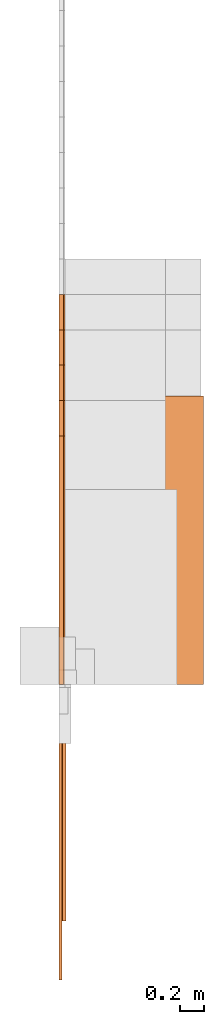
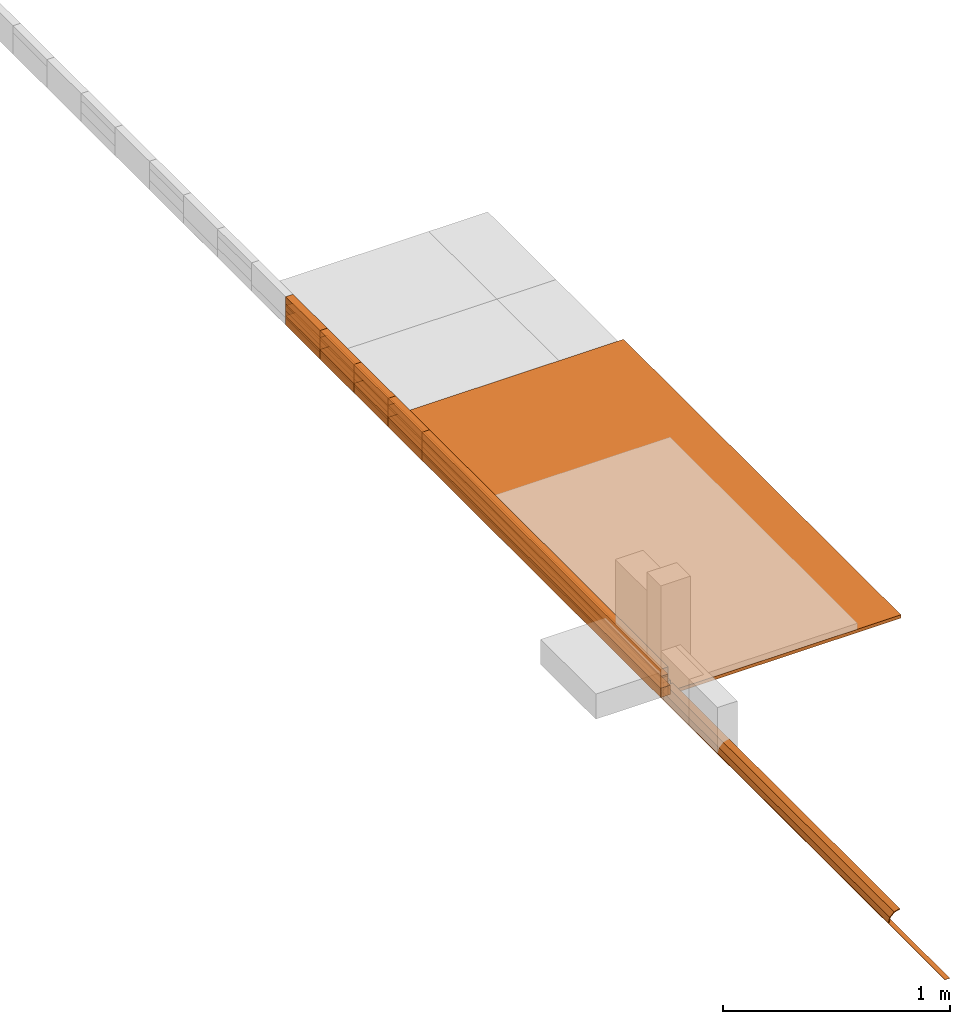
# Not in any storey, part 1 of 5: 39 proxies.
"""IFC4 model written with IfcOpenShell, lengths in metres."""

from ifc_helpers import new_model, entity, si_unit, converted_unit, direction, origin_with_axes, place, context, subcontext, project, faceted_brep, element, save


model = new_model("IFC4")

# Units and contexts
model_context = context("Model", 3, precision=1e-05, world=origin_with_axes(), true_north=direction((0.0, 1.0)))
body_context = subcontext(model_context, "Body", "Model", "MODEL_VIEW")
ifc_project = project(units=[si_unit("LENGTHUNIT", "METRE"), si_unit("AREAUNIT", "SQUARE_METRE"), si_unit("VOLUMEUNIT", "CUBIC_METRE"), converted_unit("PLANEANGLEUNIT", "DEGREE", entity("IfcPlaneAngleMeasure", 0.017453292519943295), si_unit("PLANEANGLEUNIT", "RADIAN"), dimensions=[0, 0, 0, 0, 0, 0, 0])], contexts=[model_context])

# Proxies
proxy_1_placement = place(None, origin_with_axes())
element("IfcBuildingElementProxy", 1, at=proxy_1_placement, Name="1220x2440x18", context=body_context, shape_type="Brep", body=[
    faceted_brep([(1.22, 0.0, 0.0), (1.22, 0.0, 0.018), (0.0, 0.0, 0.018), (0.0, 0.0, 0.0), (1.22, 2.44, 0.0), (1.22, 2.44, 0.018), (1.22, 0.0, 0.018), (1.22, 0.0, 0.0), (0.0, 2.44, 0.0), (0.0, 2.44, 0.018), (1.22, 2.44, 0.018), (1.22, 2.44, 0.0), (0.0, 0.0, 0.0), (0.0, 0.0, 0.018), (0.0, 2.44, 0.018), (0.0, 2.44, 0.0), (0.0, 2.44, 0.0), (1.22, 2.44, 0.0), (1.22, 0.0, 0.0), (0.0, 0.0, 0.0), (0.0, 0.0, 0.018), (1.22, 0.0, 0.018), (1.22, 2.44, 0.018), (0.0, 2.44, 0.018)], [[[0, 1, 2, 3]], [[4, 5, 6, 7]], [[8, 9, 10, 11]], [[12, 13, 14, 15]], [[16, 17, 18, 19]], [[20, 21, 22, 23]]]),
])
proxy_2_placement = place(None, origin_with_axes())
element("IfcBuildingElementProxy", 2, at=proxy_2_placement, Name="Timber 114x38x2100", context=body_context, shape_type="Brep", body=[
    faceted_brep([(0.038, 0.0, 0.0), (0.038, 0.0, 0.114), (0.0, 0.0, 0.114), (0.0, 0.0, 0.0), (0.038, 2.1, 0.0), (0.038, 2.1, 0.114), (0.038, 0.0, 0.114), (0.038, 0.0, 0.0), (0.0, 2.1, 0.0), (0.0, 2.1, 0.114), (0.038, 2.1, 0.114), (0.038, 2.1, 0.0), (0.0, 0.0, 0.0), (0.0, 0.0, 0.114), (0.0, 2.1, 0.114), (0.0, 2.1, 0.0), (0.0, 2.1, 0.0), (0.038, 2.1, 0.0), (0.038, 0.0, 0.0), (0.0, 0.0, 0.0), (0.0, 0.0, 0.114), (0.038, 0.0, 0.114), (0.038, 2.1, 0.114), (0.0, 2.1, 0.114)], [[[0, 1, 2, 3]], [[4, 5, 6, 7]], [[8, 9, 10, 11]], [[12, 13, 14, 15]], [[16, 17, 18, 19]], [[20, 21, 22, 23]]]),
])
proxy_3_placement = place(None, origin_with_axes())
element("IfcBuildingElementProxy", 3, at=proxy_3_placement, Name="Timber 114x38x2400", context=body_context, shape_type="Brep", body=[
    faceted_brep([(0.038, 0.0, 0.0), (0.038, 0.0, 0.114), (0.0, 0.0, 0.114), (0.0, 0.0, 0.0), (0.038, 2.4, 0.0), (0.038, 2.4, 0.114), (0.038, 0.0, 0.114), (0.038, 0.0, 0.0), (0.0, 2.4, 0.0), (0.0, 2.4, 0.114), (0.038, 2.4, 0.114), (0.038, 2.4, 0.0), (0.0, 0.0, 0.0), (0.0, 0.0, 0.114), (0.0, 2.4, 0.114), (0.0, 2.4, 0.0), (0.0, 2.4, 0.0), (0.038, 2.4, 0.0), (0.038, 0.0, 0.0), (0.0, 0.0, 0.0), (0.0, 0.0, 0.114), (0.038, 0.0, 0.114), (0.038, 2.4, 0.114), (0.0, 2.4, 0.114)], [[[0, 1, 2, 3]], [[4, 5, 6, 7]], [[8, 9, 10, 11]], [[12, 13, 14, 15]], [[16, 17, 18, 19]], [[20, 21, 22, 23]]]),
])
proxy_4_placement = place(None, origin_with_axes())
element("IfcBuildingElementProxy", 4, at=proxy_4_placement, Name="Timber 114x38x2700", context=body_context, shape_type="Brep", body=[
    faceted_brep([(0.038, 0.0, 0.0), (0.038, 0.0, 0.114), (0.0, 0.0, 0.114), (0.0, 0.0, 0.0), (0.038, 2.7, 0.0), (0.038, 2.7, 0.114), (0.038, 0.0, 0.114), (0.038, 0.0, 0.0), (0.0, 2.7, 0.0), (0.0, 2.7, 0.114), (0.038, 2.7, 0.114), (0.038, 2.7, 0.0), (0.0, 0.0, 0.0), (0.0, 0.0, 0.114), (0.0, 2.7, 0.114), (0.0, 2.7, 0.0), (0.0, 2.7, 0.0), (0.038, 2.7, 0.0), (0.038, 0.0, 0.0), (0.0, 0.0, 0.0), (0.0, 0.0, 0.114), (0.038, 0.0, 0.114), (0.038, 2.7, 0.114), (0.0, 2.7, 0.114)], [[[0, 1, 2, 3]], [[4, 5, 6, 7]], [[8, 9, 10, 11]], [[12, 13, 14, 15]], [[16, 17, 18, 19]], [[20, 21, 22, 23]]]),
])
proxy_5_placement = place(None, origin_with_axes())
element("IfcBuildingElementProxy", 5, at=proxy_5_placement, Name="Timber 114x38x3000", context=body_context, shape_type="Brep", body=[
    faceted_brep([(0.038, 0.0, 0.0), (0.038, 0.0, 0.114), (0.0, 0.0, 0.114), (0.0, 0.0, 0.0), (0.038, 3.0, 0.0), (0.038, 3.0, 0.114), (0.038, 0.0, 0.114), (0.038, 0.0, 0.0), (0.0, 3.0, 0.0), (0.0, 3.0, 0.114), (0.038, 3.0, 0.114), (0.038, 3.0, 0.0), (0.0, 0.0, 0.0), (0.0, 0.0, 0.114), (0.0, 3.0, 0.114), (0.0, 3.0, 0.0), (0.0, 3.0, 0.0), (0.038, 3.0, 0.0), (0.038, 0.0, 0.0), (0.0, 0.0, 0.0), (0.0, 0.0, 0.114), (0.038, 0.0, 0.114), (0.038, 3.0, 0.114), (0.0, 3.0, 0.114)], [[[0, 1, 2, 3]], [[4, 5, 6, 7]], [[8, 9, 10, 11]], [[12, 13, 14, 15]], [[16, 17, 18, 19]], [[20, 21, 22, 23]]]),
])
proxy_6_placement = place(None, origin_with_axes())
element("IfcBuildingElementProxy", 6, at=proxy_6_placement, Name="Timber 114x38x3300", context=body_context, shape_type="Brep", body=[
    faceted_brep([(0.038, 0.0, 0.0), (0.038, 0.0, 0.114), (0.0, 0.0, 0.114), (0.0, 0.0, 0.0), (0.038, 3.3, 0.0), (0.038, 3.3, 0.114), (0.038, 0.0, 0.114), (0.038, 0.0, 0.0), (0.0, 3.3, 0.0), (0.0, 3.3, 0.114), (0.038, 3.3, 0.114), (0.038, 3.3, 0.0), (0.0, 0.0, 0.0), (0.0, 0.0, 0.114), (0.0, 3.3, 0.114), (0.0, 3.3, 0.0), (0.0, 3.3, 0.0), (0.038, 3.3, 0.0), (0.038, 0.0, 0.0), (0.0, 0.0, 0.0), (0.0, 0.0, 0.114), (0.038, 0.0, 0.114), (0.038, 3.3, 0.114), (0.0, 3.3, 0.114)], [[[0, 1, 2, 3]], [[4, 5, 6, 7]], [[8, 9, 10, 11]], [[12, 13, 14, 15]], [[16, 17, 18, 19]], [[20, 21, 22, 23]]]),
])
proxy_7_placement = place(None, origin_with_axes())
element("IfcBuildingElementProxy", 7, at=proxy_7_placement, Name="Timber 38x105x2100", context=body_context, shape_type="Brep", body=[
    faceted_brep([(0.038, 0.0, 0.0), (0.038, 0.0, 0.105), (0.0, 0.0, 0.105), (0.0, 0.0, 0.0), (0.038, 2.1, 0.0), (0.038, 2.1, 0.105), (0.038, 0.0, 0.105), (0.038, 0.0, 0.0), (0.0, 2.1, 0.0), (0.0, 2.1, 0.105), (0.038, 2.1, 0.105), (0.038, 2.1, 0.0), (0.0, 0.0, 0.0), (0.0, 0.0, 0.105), (0.0, 2.1, 0.105), (0.0, 2.1, 0.0), (0.0, 2.1, 0.0), (0.038, 2.1, 0.0), (0.038, 0.0, 0.0), (0.0, 0.0, 0.0), (0.0, 0.0, 0.105), (0.038, 0.0, 0.105), (0.038, 2.1, 0.105), (0.0, 2.1, 0.105)], [[[0, 1, 2, 3]], [[4, 5, 6, 7]], [[8, 9, 10, 11]], [[12, 13, 14, 15]], [[16, 17, 18, 19]], [[20, 21, 22, 23]]]),
])
proxy_8_placement = place(None, origin_with_axes())
element("IfcBuildingElementProxy", 8, at=proxy_8_placement, Name="Timber 38x105x2400", context=body_context, shape_type="Brep", body=[
    faceted_brep([(0.038, 0.0, 0.0), (0.038, 0.0, 0.105), (0.0, 0.0, 0.105), (0.0, 0.0, 0.0), (0.038, 2.4, 0.0), (0.038, 2.4, 0.105), (0.038, 0.0, 0.105), (0.038, 0.0, 0.0), (0.0, 2.4, 0.0), (0.0, 2.4, 0.105), (0.038, 2.4, 0.105), (0.038, 2.4, 0.0), (0.0, 0.0, 0.0), (0.0, 0.0, 0.105), (0.0, 2.4, 0.105), (0.0, 2.4, 0.0), (0.0, 2.4, 0.0), (0.038, 2.4, 0.0), (0.038, 0.0, 0.0), (0.0, 0.0, 0.0), (0.0, 0.0, 0.105), (0.038, 0.0, 0.105), (0.038, 2.4, 0.105), (0.0, 2.4, 0.105)], [[[0, 1, 2, 3]], [[4, 5, 6, 7]], [[8, 9, 10, 11]], [[12, 13, 14, 15]], [[16, 17, 18, 19]], [[20, 21, 22, 23]]]),
])
proxy_9_placement = place(None, origin_with_axes())
element("IfcBuildingElementProxy", 9, at=proxy_9_placement, Name="Timber 38x105x2700", context=body_context, shape_type="Brep", body=[
    faceted_brep([(0.038, 0.0, 0.0), (0.038, 0.0, 0.105), (0.0, 0.0, 0.105), (0.0, 0.0, 0.0), (0.038, 2.7, 0.0), (0.038, 2.7, 0.105), (0.038, 0.0, 0.105), (0.038, 0.0, 0.0), (0.0, 2.7, 0.0), (0.0, 2.7, 0.105), (0.038, 2.7, 0.105), (0.038, 2.7, 0.0), (0.0, 0.0, 0.0), (0.0, 0.0, 0.105), (0.0, 2.7, 0.105), (0.0, 2.7, 0.0), (0.0, 2.7, 0.0), (0.038, 2.7, 0.0), (0.038, 0.0, 0.0), (0.0, 0.0, 0.0), (0.0, 0.0, 0.105), (0.038, 0.0, 0.105), (0.038, 2.7, 0.105), (0.0, 2.7, 0.105)], [[[0, 1, 2, 3]], [[4, 5, 6, 7]], [[8, 9, 10, 11]], [[12, 13, 14, 15]], [[16, 17, 18, 19]], [[20, 21, 22, 23]]]),
])
proxy_10_placement = place(None, origin_with_axes())
element("IfcBuildingElementProxy", 10, at=proxy_10_placement, Name="Timber 38x105x3000", context=body_context, shape_type="Brep", body=[
    faceted_brep([(0.038, 0.0, 0.0), (0.038, 0.0, 0.105), (0.0, 0.0, 0.105), (0.0, 0.0, 0.0), (0.038, 3.0, 0.0), (0.038, 3.0, 0.105), (0.038, 0.0, 0.105), (0.038, 0.0, 0.0), (0.0, 3.0, 0.0), (0.0, 3.0, 0.105), (0.038, 3.0, 0.105), (0.038, 3.0, 0.0), (0.0, 0.0, 0.0), (0.0, 0.0, 0.105), (0.0, 3.0, 0.105), (0.0, 3.0, 0.0), (0.0, 3.0, 0.0), (0.038, 3.0, 0.0), (0.038, 0.0, 0.0), (0.0, 0.0, 0.0), (0.0, 0.0, 0.105), (0.038, 0.0, 0.105), (0.038, 3.0, 0.105), (0.0, 3.0, 0.105)], [[[0, 1, 2, 3]], [[4, 5, 6, 7]], [[8, 9, 10, 11]], [[12, 13, 14, 15]], [[16, 17, 18, 19]], [[20, 21, 22, 23]]]),
])
proxy_11_placement = place(None, origin_with_axes())
element("IfcBuildingElementProxy", 11, at=proxy_11_placement, Name="Timber 38x105x3300", context=body_context, shape_type="Brep", body=[
    faceted_brep([(0.038, 0.0, 0.0), (0.038, 0.0, 0.105), (0.0, 0.0, 0.105), (0.0, 0.0, 0.0), (0.038, 3.3, 0.0), (0.038, 3.3, 0.105), (0.038, 0.0, 0.105), (0.038, 0.0, 0.0), (0.0, 3.3, 0.0), (0.0, 3.3, 0.105), (0.038, 3.3, 0.105), (0.038, 3.3, 0.0), (0.0, 0.0, 0.0), (0.0, 0.0, 0.105), (0.0, 3.3, 0.105), (0.0, 3.3, 0.0), (0.0, 3.3, 0.0), (0.038, 3.3, 0.0), (0.038, 0.0, 0.0), (0.0, 0.0, 0.0), (0.0, 0.0, 0.105), (0.038, 0.0, 0.105), (0.038, 3.3, 0.105), (0.0, 3.3, 0.105)], [[[0, 1, 2, 3]], [[4, 5, 6, 7]], [[8, 9, 10, 11]], [[12, 13, 14, 15]], [[16, 17, 18, 19]], [[20, 21, 22, 23]]]),
])
proxy_12_placement = place(None, origin_with_axes())
element("IfcBuildingElementProxy", 12, at=proxy_12_placement, Name="Timber 38x38x2100", context=body_context, shape_type="Brep", body=[
    faceted_brep([(0.038, 0.0, 0.0), (0.038, 0.0, 0.038), (0.0, 0.0, 0.038), (0.0, 0.0, 0.0), (0.038, 2.1, 0.0), (0.038, 2.1, 0.038), (0.038, 0.0, 0.038), (0.038, 0.0, 0.0), (0.0, 2.1, 0.0), (0.0, 2.1, 0.038), (0.038, 2.1, 0.038), (0.038, 2.1, 0.0), (0.0, 0.0, 0.0), (0.0, 0.0, 0.038), (0.0, 2.1, 0.038), (0.0, 2.1, 0.0), (0.0, 2.1, 0.0), (0.038, 2.1, 0.0), (0.038, 0.0, 0.0), (0.0, 0.0, 0.0), (0.0, 0.0, 0.038), (0.038, 0.0, 0.038), (0.038, 2.1, 0.038), (0.0, 2.1, 0.038)], [[[0, 1, 2, 3]], [[4, 5, 6, 7]], [[8, 9, 10, 11]], [[12, 13, 14, 15]], [[16, 17, 18, 19]], [[20, 21, 22, 23]]]),
])
proxy_13_placement = place(None, origin_with_axes())
element("IfcBuildingElementProxy", 13, at=proxy_13_placement, Name="Timber 38x38x2400", context=body_context, shape_type="Brep", body=[
    faceted_brep([(0.038, 0.0, 0.0), (0.038, 0.0, 0.038), (0.0, 0.0, 0.038), (0.0, 0.0, 0.0), (0.038, 2.4, 0.0), (0.038, 2.4, 0.038), (0.038, 0.0, 0.038), (0.038, 0.0, 0.0), (0.0, 2.4, 0.0), (0.0, 2.4, 0.038), (0.038, 2.4, 0.038), (0.038, 2.4, 0.0), (0.0, 0.0, 0.0), (0.0, 0.0, 0.038), (0.0, 2.4, 0.038), (0.0, 2.4, 0.0), (0.0, 2.4, 0.0), (0.038, 2.4, 0.0), (0.038, 0.0, 0.0), (0.0, 0.0, 0.0), (0.0, 0.0, 0.038), (0.038, 0.0, 0.038), (0.038, 2.4, 0.038), (0.0, 2.4, 0.038)], [[[0, 1, 2, 3]], [[4, 5, 6, 7]], [[8, 9, 10, 11]], [[12, 13, 14, 15]], [[16, 17, 18, 19]], [[20, 21, 22, 23]]]),
])
proxy_14_placement = place(None, origin_with_axes())
element("IfcBuildingElementProxy", 14, at=proxy_14_placement, Name="Timber 38x38x2700", context=body_context, shape_type="Brep", body=[
    faceted_brep([(0.038, 0.0, 0.0), (0.038, 0.0, 0.038), (0.0, 0.0, 0.038), (0.0, 0.0, 0.0), (0.038, 2.7, 0.0), (0.038, 2.7, 0.038), (0.038, 0.0, 0.038), (0.038, 0.0, 0.0), (0.0, 2.7, 0.0), (0.0, 2.7, 0.038), (0.038, 2.7, 0.038), (0.038, 2.7, 0.0), (0.0, 0.0, 0.0), (0.0, 0.0, 0.038), (0.0, 2.7, 0.038), (0.0, 2.7, 0.0), (0.0, 2.7, 0.0), (0.038, 2.7, 0.0), (0.038, 0.0, 0.0), (0.0, 0.0, 0.0), (0.0, 0.0, 0.038), (0.038, 0.0, 0.038), (0.038, 2.7, 0.038), (0.0, 2.7, 0.038)], [[[0, 1, 2, 3]], [[4, 5, 6, 7]], [[8, 9, 10, 11]], [[12, 13, 14, 15]], [[16, 17, 18, 19]], [[20, 21, 22, 23]]]),
])
proxy_15_placement = place(None, origin_with_axes())
element("IfcBuildingElementProxy", 15, at=proxy_15_placement, Name="Timber 38x38x3000", context=body_context, shape_type="Brep", body=[
    faceted_brep([(0.038, 0.0, 0.0), (0.038, 0.0, 0.038), (0.0, 0.0, 0.038), (0.0, 0.0, 0.0), (0.038, 3.0, 0.0), (0.038, 3.0, 0.038), (0.038, 0.0, 0.038), (0.038, 0.0, 0.0), (0.0, 3.0, 0.0), (0.0, 3.0, 0.038), (0.038, 3.0, 0.038), (0.038, 3.0, 0.0), (0.0, 0.0, 0.0), (0.0, 0.0, 0.038), (0.0, 3.0, 0.038), (0.0, 3.0, 0.0), (0.0, 3.0, 0.0), (0.038, 3.0, 0.0), (0.038, 0.0, 0.0), (0.0, 0.0, 0.0), (0.0, 0.0, 0.038), (0.038, 0.0, 0.038), (0.038, 3.0, 0.038), (0.0, 3.0, 0.038)], [[[0, 1, 2, 3]], [[4, 5, 6, 7]], [[8, 9, 10, 11]], [[12, 13, 14, 15]], [[16, 17, 18, 19]], [[20, 21, 22, 23]]]),
])
proxy_16_placement = place(None, origin_with_axes())
element("IfcBuildingElementProxy", 16, at=proxy_16_placement, Name="Timber 38x38x3300", context=body_context, shape_type="Brep", body=[
    faceted_brep([(0.038, 0.0, 0.0), (0.038, 0.0, 0.038), (0.0, 0.0, 0.038), (0.0, 0.0, 0.0), (0.038, 3.3, 0.0), (0.038, 3.3, 0.038), (0.038, 0.0, 0.038), (0.038, 0.0, 0.0), (0.0, 3.3, 0.0), (0.0, 3.3, 0.038), (0.038, 3.3, 0.038), (0.038, 3.3, 0.0), (0.0, 0.0, 0.0), (0.0, 0.0, 0.038), (0.0, 3.3, 0.038), (0.0, 3.3, 0.0), (0.0, 3.3, 0.0), (0.038, 3.3, 0.0), (0.038, 0.0, 0.0), (0.0, 0.0, 0.0), (0.0, 0.0, 0.038), (0.038, 0.0, 0.038), (0.038, 3.3, 0.038), (0.0, 3.3, 0.038)], [[[0, 1, 2, 3]], [[4, 5, 6, 7]], [[8, 9, 10, 11]], [[12, 13, 14, 15]], [[16, 17, 18, 19]], [[20, 21, 22, 23]]]),
])
proxy_17_placement = place(None, origin_with_axes())
element("IfcBuildingElementProxy", 17, at=proxy_17_placement, Name="Timber 38x50x2100", context=body_context, shape_type="Brep", body=[
    faceted_brep([(0.038, 0.0, 0.0), (0.038, 0.0, 0.05), (0.0, 0.0, 0.05), (0.0, 0.0, 0.0), (0.038, 2.1, 0.0), (0.038, 2.1, 0.05), (0.038, 0.0, 0.05), (0.038, 0.0, 0.0), (0.0, 2.1, 0.0), (0.0, 2.1, 0.05), (0.038, 2.1, 0.05), (0.038, 2.1, 0.0), (0.0, 0.0, 0.0), (0.0, 0.0, 0.05), (0.0, 2.1, 0.05), (0.0, 2.1, 0.0), (0.0, 2.1, 0.0), (0.038, 2.1, 0.0), (0.038, 0.0, 0.0), (0.0, 0.0, 0.0), (0.0, 0.0, 0.05), (0.038, 0.0, 0.05), (0.038, 2.1, 0.05), (0.0, 2.1, 0.05)], [[[0, 1, 2, 3]], [[4, 5, 6, 7]], [[8, 9, 10, 11]], [[12, 13, 14, 15]], [[16, 17, 18, 19]], [[20, 21, 22, 23]]]),
])
proxy_18_placement = place(None, origin_with_axes())
element("IfcBuildingElementProxy", 18, at=proxy_18_placement, Name="Timber 38x50x2300", context=body_context, shape_type="Brep", body=[
    faceted_brep([(0.038, 0.0, 0.0), (0.038, 0.0, 0.05), (0.0, 0.0, 0.05), (0.0, 0.0, 0.0), (0.038, 2.4, 0.0), (0.038, 2.4, 0.05), (0.038, 0.0, 0.05), (0.038, 0.0, 0.0), (0.0, 2.4, 0.0), (0.0, 2.4, 0.05), (0.038, 2.4, 0.05), (0.038, 2.4, 0.0), (0.0, 0.0, 0.0), (0.0, 0.0, 0.05), (0.0, 2.4, 0.05), (0.0, 2.4, 0.0), (0.0, 2.4, 0.0), (0.038, 2.4, 0.0), (0.038, 0.0, 0.0), (0.0, 0.0, 0.0), (0.0, 0.0, 0.05), (0.038, 0.0, 0.05), (0.038, 2.4, 0.05), (0.0, 2.4, 0.05)], [[[0, 1, 2, 3]], [[4, 5, 6, 7]], [[8, 9, 10, 11]], [[12, 13, 14, 15]], [[16, 17, 18, 19]], [[20, 21, 22, 23]]]),
])
proxy_19_placement = place(None, origin_with_axes())
element("IfcBuildingElementProxy", 19, at=proxy_19_placement, Name="Timber 38x50x2700", context=body_context, shape_type="Brep", body=[
    faceted_brep([(0.038, 0.0, 0.0), (0.038, 0.0, 0.05), (0.0, 0.0, 0.05), (0.0, 0.0, 0.0), (0.038, 2.7, 0.0), (0.038, 2.7, 0.05), (0.038, 0.0, 0.05), (0.038, 0.0, 0.0), (0.0, 2.7, 0.0), (0.0, 2.7, 0.05), (0.038, 2.7, 0.05), (0.038, 2.7, 0.0), (0.0, 0.0, 0.0), (0.0, 0.0, 0.05), (0.0, 2.7, 0.05), (0.0, 2.7, 0.0), (0.0, 2.7, 0.0), (0.038, 2.7, 0.0), (0.038, 0.0, 0.0), (0.0, 0.0, 0.0), (0.0, 0.0, 0.05), (0.038, 0.0, 0.05), (0.038, 2.7, 0.05), (0.0, 2.7, 0.05)], [[[0, 1, 2, 3]], [[4, 5, 6, 7]], [[8, 9, 10, 11]], [[12, 13, 14, 15]], [[16, 17, 18, 19]], [[20, 21, 22, 23]]]),
])
proxy_20_placement = place(None, origin_with_axes())
element("IfcBuildingElementProxy", 20, at=proxy_20_placement, Name="Timber 38x50x3000", context=body_context, shape_type="Brep", body=[
    faceted_brep([(0.038, 0.0, 0.0), (0.038, 0.0, 0.05), (0.0, 0.0, 0.05), (0.0, 0.0, 0.0), (0.038, 3.0, 0.0), (0.038, 3.0, 0.05), (0.038, 0.0, 0.05), (0.038, 0.0, 0.0), (0.0, 3.0, 0.0), (0.0, 3.0, 0.05), (0.038, 3.0, 0.05), (0.038, 3.0, 0.0), (0.0, 0.0, 0.0), (0.0, 0.0, 0.05), (0.0, 3.0, 0.05), (0.0, 3.0, 0.0), (0.0, 3.0, 0.0), (0.038, 3.0, 0.0), (0.038, 0.0, 0.0), (0.0, 0.0, 0.0), (0.0, 0.0, 0.05), (0.038, 0.0, 0.05), (0.038, 3.0, 0.05), (0.0, 3.0, 0.05)], [[[0, 1, 2, 3]], [[4, 5, 6, 7]], [[8, 9, 10, 11]], [[12, 13, 14, 15]], [[16, 17, 18, 19]], [[20, 21, 22, 23]]]),
])
proxy_21_placement = place(None, origin_with_axes())
element("IfcBuildingElementProxy", 21, at=proxy_21_placement, Name="Timber 38x50x3300", context=body_context, shape_type="Brep", body=[
    faceted_brep([(0.038, 0.0, 0.0), (0.038, 0.0, 0.05), (0.0, 0.0, 0.05), (0.0, 0.0, 0.0), (0.038, 3.3, 0.0), (0.038, 3.3, 0.05), (0.038, 0.0, 0.05), (0.038, 0.0, 0.0), (0.0, 3.3, 0.0), (0.0, 3.3, 0.05), (0.038, 3.3, 0.05), (0.038, 3.3, 0.0), (0.0, 0.0, 0.0), (0.0, 0.0, 0.05), (0.0, 3.3, 0.05), (0.0, 3.3, 0.0), (0.0, 3.3, 0.0), (0.038, 3.3, 0.0), (0.038, 0.0, 0.0), (0.0, 0.0, 0.0), (0.0, 0.0, 0.05), (0.038, 0.0, 0.05), (0.038, 3.3, 0.05), (0.0, 3.3, 0.05)], [[[0, 1, 2, 3]], [[4, 5, 6, 7]], [[8, 9, 10, 11]], [[12, 13, 14, 15]], [[16, 17, 18, 19]], [[20, 21, 22, 23]]]),
])
proxy_22_placement = place(None, origin_with_axes())
element("IfcBuildingElementProxy", 22, at=proxy_22_placement, Name="Timber 38x152x2100", context=body_context, shape_type="Brep", body=[
    faceted_brep([(0.038, 0.0, 0.0), (0.038, 0.0, 0.152), (0.0, 0.0, 0.152), (0.0, 0.0, 0.0), (0.038, 2.1, 0.0), (0.038, 2.1, 0.152), (0.038, 0.0, 0.152), (0.038, 0.0, 0.0), (0.0, 2.1, 0.0), (0.0, 2.1, 0.152), (0.038, 2.1, 0.152), (0.038, 2.1, 0.0), (0.0, 0.0, 0.0), (0.0, 0.0, 0.152), (0.0, 2.1, 0.152), (0.0, 2.1, 0.0), (0.0, 2.1, 0.0), (0.038, 2.1, 0.0), (0.038, 0.0, 0.0), (0.0, 0.0, 0.0), (0.0, 0.0, 0.152), (0.038, 0.0, 0.152), (0.038, 2.1, 0.152), (0.0, 2.1, 0.152)], [[[0, 1, 2, 3]], [[4, 5, 6, 7]], [[8, 9, 10, 11]], [[12, 13, 14, 15]], [[16, 17, 18, 19]], [[20, 21, 22, 23]]]),
])
proxy_23_placement = place(None, origin_with_axes())
element("IfcBuildingElementProxy", 23, at=proxy_23_placement, Name="Timber 38x152x2400", context=body_context, shape_type="Brep", body=[
    faceted_brep([(0.038, 0.0, 0.0), (0.038, 0.0, 0.152), (0.0, 0.0, 0.152), (0.0, 0.0, 0.0), (0.038, 2.4, 0.0), (0.038, 2.4, 0.152), (0.038, 0.0, 0.152), (0.038, 0.0, 0.0), (0.0, 2.4, 0.0), (0.0, 2.4, 0.152), (0.038, 2.4, 0.152), (0.038, 2.4, 0.0), (0.0, 0.0, 0.0), (0.0, 0.0, 0.152), (0.0, 2.4, 0.152), (0.0, 2.4, 0.0), (0.0, 2.4, 0.0), (0.038, 2.4, 0.0), (0.038, 0.0, 0.0), (0.0, 0.0, 0.0), (0.0, 0.0, 0.152), (0.038, 0.0, 0.152), (0.038, 2.4, 0.152), (0.0, 2.4, 0.152)], [[[0, 1, 2, 3]], [[4, 5, 6, 7]], [[8, 9, 10, 11]], [[12, 13, 14, 15]], [[16, 17, 18, 19]], [[20, 21, 22, 23]]]),
])
proxy_24_placement = place(None, origin_with_axes())
element("IfcBuildingElementProxy", 24, at=proxy_24_placement, Name="Timber 38x152x2700", context=body_context, shape_type="Brep", body=[
    faceted_brep([(0.038, 0.0, 0.0), (0.038, 0.0, 0.152), (0.0, 0.0, 0.152), (0.0, 0.0, 0.0), (0.038, 2.7, 0.0), (0.038, 2.7, 0.152), (0.038, 0.0, 0.152), (0.038, 0.0, 0.0), (0.0, 2.7, 0.0), (0.0, 2.7, 0.152), (0.038, 2.7, 0.152), (0.038, 2.7, 0.0), (0.0, 0.0, 0.0), (0.0, 0.0, 0.152), (0.0, 2.7, 0.152), (0.0, 2.7, 0.0), (0.0, 2.7, 0.0), (0.038, 2.7, 0.0), (0.038, 0.0, 0.0), (0.0, 0.0, 0.0), (0.0, 0.0, 0.152), (0.038, 0.0, 0.152), (0.038, 2.7, 0.152), (0.0, 2.7, 0.152)], [[[0, 1, 2, 3]], [[4, 5, 6, 7]], [[8, 9, 10, 11]], [[12, 13, 14, 15]], [[16, 17, 18, 19]], [[20, 21, 22, 23]]]),
])
proxy_25_placement = place(None, origin_with_axes())
element("IfcBuildingElementProxy", 25, at=proxy_25_placement, Name="Timber 38x152x3000", context=body_context, shape_type="Brep", body=[
    faceted_brep([(0.038, 0.0, 0.0), (0.038, 0.0, 0.152), (0.0, 0.0, 0.152), (0.0, 0.0, 0.0), (0.038, 3.0, 0.0), (0.038, 3.0, 0.152), (0.038, 0.0, 0.152), (0.038, 0.0, 0.0), (0.0, 3.0, 0.0), (0.0, 3.0, 0.152), (0.038, 3.0, 0.152), (0.038, 3.0, 0.0), (0.0, 0.0, 0.0), (0.0, 0.0, 0.152), (0.0, 3.0, 0.152), (0.0, 3.0, 0.0), (0.0, 3.0, 0.0), (0.038, 3.0, 0.0), (0.038, 0.0, 0.0), (0.0, 0.0, 0.0), (0.0, 0.0, 0.152), (0.038, 0.0, 0.152), (0.038, 3.0, 0.152), (0.0, 3.0, 0.152)], [[[0, 1, 2, 3]], [[4, 5, 6, 7]], [[8, 9, 10, 11]], [[12, 13, 14, 15]], [[16, 17, 18, 19]], [[20, 21, 22, 23]]]),
])
proxy_26_placement = place(None, origin_with_axes())
element("IfcBuildingElementProxy", 26, at=proxy_26_placement, Name="Timber 38x152x3300", context=body_context, shape_type="Brep", body=[
    faceted_brep([(0.038, 0.0, 0.0), (0.038, 0.0, 0.152), (0.0, 0.0, 0.152), (0.0, 0.0, 0.0), (0.038, 3.3, 0.0), (0.038, 3.3, 0.152), (0.038, 0.0, 0.152), (0.038, 0.0, 0.0), (0.0, 3.3, 0.0), (0.0, 3.3, 0.152), (0.038, 3.3, 0.152), (0.038, 3.3, 0.0), (0.0, 0.0, 0.0), (0.0, 0.0, 0.152), (0.0, 3.3, 0.152), (0.0, 3.3, 0.0), (0.0, 3.3, 0.0), (0.038, 3.3, 0.0), (0.038, 0.0, 0.0), (0.0, 0.0, 0.0), (0.0, 0.0, 0.152), (0.038, 0.0, 0.152), (0.038, 3.3, 0.152), (0.0, 3.3, 0.152)], [[[0, 1, 2, 3]], [[4, 5, 6, 7]], [[8, 9, 10, 11]], [[12, 13, 14, 15]], [[16, 17, 18, 19]], [[20, 21, 22, 23]]]),
])
proxy_27_placement = place(None, origin_with_axes())
element("IfcBuildingElementProxy", 27, at=proxy_27_placement, Name="Timber 38x76x2100", context=body_context, shape_type="Brep", body=[
    faceted_brep([(0.038, 0.0, 0.0), (0.038, 0.0, 0.076), (0.0, 0.0, 0.076), (0.0, 0.0, 0.0), (0.038, 2.1, 0.0), (0.038, 2.1, 0.076), (0.038, 0.0, 0.076), (0.038, 0.0, 0.0), (0.0, 2.1, 0.0), (0.0, 2.1, 0.076), (0.038, 2.1, 0.076), (0.038, 2.1, 0.0), (0.0, 0.0, 0.0), (0.0, 0.0, 0.076), (0.0, 2.1, 0.076), (0.0, 2.1, 0.0), (0.0, 2.1, 0.0), (0.038, 2.1, 0.0), (0.038, 0.0, 0.0), (0.0, 0.0, 0.0), (0.0, 0.0, 0.076), (0.038, 0.0, 0.076), (0.038, 2.1, 0.076), (0.0, 2.1, 0.076)], [[[0, 1, 2, 3]], [[4, 5, 6, 7]], [[8, 9, 10, 11]], [[12, 13, 14, 15]], [[16, 17, 18, 19]], [[20, 21, 22, 23]]]),
])
proxy_28_placement = place(None, origin_with_axes())
element("IfcBuildingElementProxy", 28, at=proxy_28_placement, Name="Timber 38x76x2400", context=body_context, shape_type="Brep", body=[
    faceted_brep([(0.038, 0.0, 0.0), (0.038, 0.0, 0.076), (0.0, 0.0, 0.076), (0.0, 0.0, 0.0), (0.038, 2.4, 0.0), (0.038, 2.4, 0.076), (0.038, 0.0, 0.076), (0.038, 0.0, 0.0), (0.0, 2.4, 0.0), (0.0, 2.4, 0.076), (0.038, 2.4, 0.076), (0.038, 2.4, 0.0), (0.0, 0.0, 0.0), (0.0, 0.0, 0.076), (0.0, 2.4, 0.076), (0.0, 2.4, 0.0), (0.0, 2.4, 0.0), (0.038, 2.4, 0.0), (0.038, 0.0, 0.0), (0.0, 0.0, 0.0), (0.0, 0.0, 0.076), (0.038, 0.0, 0.076), (0.038, 2.4, 0.076), (0.0, 2.4, 0.076)], [[[0, 1, 2, 3]], [[4, 5, 6, 7]], [[8, 9, 10, 11]], [[12, 13, 14, 15]], [[16, 17, 18, 19]], [[20, 21, 22, 23]]]),
])
proxy_29_placement = place(None, origin_with_axes())
element("IfcBuildingElementProxy", 29, at=proxy_29_placement, Name="Timber 38x76x2700", context=body_context, shape_type="Brep", body=[
    faceted_brep([(0.038, 0.0, 0.0), (0.038, 0.0, 0.076), (0.0, 0.0, 0.076), (0.0, 0.0, 0.0), (0.038, 2.7, 0.0), (0.038, 2.7, 0.076), (0.038, 0.0, 0.076), (0.038, 0.0, 0.0), (0.0, 2.7, 0.0), (0.0, 2.7, 0.076), (0.038, 2.7, 0.076), (0.038, 2.7, 0.0), (0.0, 0.0, 0.0), (0.0, 0.0, 0.076), (0.0, 2.7, 0.076), (0.0, 2.7, 0.0), (0.0, 2.7, 0.0), (0.038, 2.7, 0.0), (0.038, 0.0, 0.0), (0.0, 0.0, 0.0), (0.0, 0.0, 0.076), (0.038, 0.0, 0.076), (0.038, 2.7, 0.076), (0.0, 2.7, 0.076)], [[[0, 1, 2, 3]], [[4, 5, 6, 7]], [[8, 9, 10, 11]], [[12, 13, 14, 15]], [[16, 17, 18, 19]], [[20, 21, 22, 23]]]),
])
proxy_30_placement = place(None, origin_with_axes())
element("IfcBuildingElementProxy", 30, at=proxy_30_placement, Name="Timber 38x76x3000", context=body_context, shape_type="Brep", body=[
    faceted_brep([(0.038, 0.0, 0.0), (0.038, 0.0, 0.076), (0.0, 0.0, 0.076), (0.0, 0.0, 0.0), (0.038, 3.0, 0.0), (0.038, 3.0, 0.076), (0.038, 0.0, 0.076), (0.038, 0.0, 0.0), (0.0, 3.0, 0.0), (0.0, 3.0, 0.076), (0.038, 3.0, 0.076), (0.038, 3.0, 0.0), (0.0, 0.0, 0.0), (0.0, 0.0, 0.076), (0.0, 3.0, 0.076), (0.0, 3.0, 0.0), (0.0, 3.0, 0.0), (0.038, 3.0, 0.0), (0.038, 0.0, 0.0), (0.0, 0.0, 0.0), (0.0, 0.0, 0.076), (0.038, 0.0, 0.076), (0.038, 3.0, 0.076), (0.0, 3.0, 0.076)], [[[0, 1, 2, 3]], [[4, 5, 6, 7]], [[8, 9, 10, 11]], [[12, 13, 14, 15]], [[16, 17, 18, 19]], [[20, 21, 22, 23]]]),
])
proxy_31_placement = place(None, origin_with_axes())
element("IfcBuildingElementProxy", 31, at=proxy_31_placement, Name="Timber 38x76x3300", context=body_context, shape_type="Brep", body=[
    faceted_brep([(0.038, 0.0, 0.0), (0.038, 0.0, 0.076), (0.0, 0.0, 0.076), (0.0, 0.0, 0.0), (0.038, 3.3, 0.0), (0.038, 3.3, 0.076), (0.038, 0.0, 0.076), (0.038, 0.0, 0.0), (0.0, 3.3, 0.0), (0.0, 3.3, 0.076), (0.038, 3.3, 0.076), (0.038, 3.3, 0.0), (0.0, 0.0, 0.0), (0.0, 0.0, 0.076), (0.0, 3.3, 0.076), (0.0, 3.3, 0.0), (0.0, 3.3, 0.0), (0.038, 3.3, 0.0), (0.038, 0.0, 0.0), (0.0, 0.0, 0.0), (0.0, 0.0, 0.076), (0.038, 0.0, 0.076), (0.038, 3.3, 0.076), (0.0, 3.3, 0.076)], [[[0, 1, 2, 3]], [[4, 5, 6, 7]], [[8, 9, 10, 11]], [[12, 13, 14, 15]], [[16, 17, 18, 19]], [[20, 21, 22, 23]]]),
])
proxy_32_placement = place(None, origin_with_axes())
element("IfcBuildingElementProxy", 32, at=proxy_32_placement, Name="Timber 50x50x2100", context=body_context, shape_type="Brep", body=[
    faceted_brep([(0.0, 2.1, 0.0), (0.0, 2.1, 0.05), (0.05, 2.1, 0.05), (0.05, 2.1, 0.0), (0.05, 2.1, 0.0), (0.05, 2.1, 0.05), (0.05, 0.0, 0.05), (0.05, 0.0, 0.0), (0.05, 0.0, 0.0), (0.05, 0.0, 0.05), (0.0, 0.0, 0.05), (0.0, 0.0, 0.0), (0.0, 0.0, 0.0), (0.0, 0.0, 0.05), (0.0, 2.1, 0.05), (0.0, 2.1, 0.0), (0.05, 0.0, 0.0), (0.0, 0.0, 0.0), (0.0, 2.1, 0.0), (0.05, 2.1, 0.0), (0.05, 2.1, 0.05), (0.0, 2.1, 0.05), (0.0, 0.0, 0.05), (0.05, 0.0, 0.05)], [[[0, 1, 2, 3]], [[4, 5, 6, 7]], [[8, 9, 10, 11]], [[12, 13, 14, 15]], [[16, 17, 18, 19]], [[20, 21, 22, 23]]]),
])
proxy_33_placement = place(None, origin_with_axes())
element("IfcBuildingElementProxy", 33, at=proxy_33_placement, Name="Timber 50x50x2400", context=body_context, shape_type="Brep", body=[
    faceted_brep([(0.0, 2.4, 0.0), (0.0, 2.4, 0.05), (0.05, 2.4, 0.05), (0.05, 2.4, 0.0), (0.05, 2.4, 0.0), (0.05, 2.4, 0.05), (0.05, 0.0, 0.05), (0.05, 0.0, 0.0), (0.05, 0.0, 0.0), (0.05, 0.0, 0.05), (0.0, 0.0, 0.05), (0.0, 0.0, 0.0), (0.0, 0.0, 0.0), (0.0, 0.0, 0.05), (0.0, 2.4, 0.05), (0.0, 2.4, 0.0), (0.05, 0.0, 0.0), (0.0, 0.0, 0.0), (0.0, 2.4, 0.0), (0.05, 2.4, 0.0), (0.05, 2.4, 0.05), (0.0, 2.4, 0.05), (0.0, 0.0, 0.05), (0.05, 0.0, 0.05)], [[[0, 1, 2, 3]], [[4, 5, 6, 7]], [[8, 9, 10, 11]], [[12, 13, 14, 15]], [[16, 17, 18, 19]], [[20, 21, 22, 23]]]),
])
proxy_34_placement = place(None, origin_with_axes())
element("IfcBuildingElementProxy", 34, at=proxy_34_placement, Name="Timber 50x50x2700", context=body_context, shape_type="Brep", body=[
    faceted_brep([(0.0, 2.7, 0.0), (0.0, 2.7, 0.05), (0.05, 2.7, 0.05), (0.05, 2.7, 0.0), (0.05, 2.7, 0.0), (0.05, 2.7, 0.05), (0.05, 0.0, 0.05), (0.05, 0.0, 0.0), (0.05, 0.0, 0.0), (0.05, 0.0, 0.05), (0.0, 0.0, 0.05), (0.0, 0.0, 0.0), (0.0, 0.0, 0.0), (0.0, 0.0, 0.05), (0.0, 2.7, 0.05), (0.0, 2.7, 0.0), (0.05, 0.0, 0.0), (0.0, 0.0, 0.0), (0.0, 2.7, 0.0), (0.05, 2.7, 0.0), (0.05, 2.7, 0.05), (0.0, 2.7, 0.05), (0.0, 0.0, 0.05), (0.05, 0.0, 0.05)], [[[0, 1, 2, 3]], [[4, 5, 6, 7]], [[8, 9, 10, 11]], [[12, 13, 14, 15]], [[16, 17, 18, 19]], [[20, 21, 22, 23]]]),
])
proxy_35_placement = place(None, origin_with_axes())
element("IfcBuildingElementProxy", 35, at=proxy_35_placement, Name="Timber 50x50x3000", context=body_context, shape_type="Brep", body=[
    faceted_brep([(0.0, 3.0, 0.0), (0.0, 3.0, 0.05), (0.05, 3.0, 0.05), (0.05, 3.0, 0.0), (0.05, 3.0, 0.0), (0.05, 3.0, 0.05), (0.05, 0.0, 0.05), (0.05, 0.0, 0.0), (0.05, 0.0, 0.0), (0.05, 0.0, 0.05), (0.0, 0.0, 0.05), (0.0, 0.0, 0.0), (0.0, 0.0, 0.0), (0.0, 0.0, 0.05), (0.0, 3.0, 0.05), (0.0, 3.0, 0.0), (0.05, 0.0, 0.0), (0.0, 0.0, 0.0), (0.0, 3.0, 0.0), (0.05, 3.0, 0.0), (0.05, 3.0, 0.05), (0.0, 3.0, 0.05), (0.0, 0.0, 0.05), (0.05, 0.0, 0.05)], [[[0, 1, 2, 3]], [[4, 5, 6, 7]], [[8, 9, 10, 11]], [[12, 13, 14, 15]], [[16, 17, 18, 19]], [[20, 21, 22, 23]]]),
])
proxy_36_placement = place(None, origin_with_axes())
element("IfcBuildingElementProxy", 36, at=proxy_36_placement, Name="Timber 50x50x3300", context=body_context, shape_type="Brep", body=[
    faceted_brep([(0.05, 0.0, 0.0), (0.05, 0.0, 0.05), (0.0, 0.0, 0.05), (0.0, 0.0, 0.0), (0.05, 3.3, 0.0), (0.05, 3.3, 0.05), (0.05, 0.0, 0.05), (0.05, 0.0, 0.0), (0.0, 3.3, 0.0), (0.0, 3.3, 0.05), (0.05, 3.3, 0.05), (0.05, 3.3, 0.0), (0.0, 0.0, 0.0), (0.0, 0.0, 0.05), (0.0, 3.3, 0.05), (0.0, 3.3, 0.0), (0.0, 3.3, 0.0), (0.05, 3.3, 0.0), (0.05, 0.0, 0.0), (0.0, 0.0, 0.0), (0.0, 0.0, 0.05), (0.05, 0.0, 0.05), (0.05, 3.3, 0.05), (0.0, 3.3, 0.05)], [[[0, 1, 2, 3]], [[4, 5, 6, 7]], [[8, 9, 10, 11]], [[12, 13, 14, 15]], [[16, 17, 18, 19]], [[20, 21, 22, 23]]]),
])
proxy_37_placement = place(None, origin_with_axes())
element("IfcBuildingElementProxy", 37, at=proxy_37_placement, Name="Timber 50x76x2100", context=body_context, shape_type="Brep", body=[
    faceted_brep([(0.0, 2.1, 0.0), (0.0, 2.1, 0.076), (0.05, 2.1, 0.076), (0.05, 2.1, 0.0), (0.05, 2.1, 0.0), (0.05, 2.1, 0.076), (0.05, 0.0, 0.076), (0.05, 0.0, 0.0), (0.05, 0.0, 0.0), (0.05, 0.0, 0.076), (0.0, 0.0, 0.076), (0.0, 0.0, 0.0), (0.0, 0.0, 0.0), (0.0, 0.0, 0.076), (0.0, 2.1, 0.076), (0.0, 2.1, 0.0), (0.05, 0.0, 0.0), (0.0, 0.0, 0.0), (0.0, 2.1, 0.0), (0.05, 2.1, 0.0), (0.05, 2.1, 0.076), (0.0, 2.1, 0.076), (0.0, 0.0, 0.076), (0.05, 0.0, 0.076)], [[[0, 1, 2, 3]], [[4, 5, 6, 7]], [[8, 9, 10, 11]], [[12, 13, 14, 15]], [[16, 17, 18, 19]], [[20, 21, 22, 23]]]),
])
proxy_38_placement = place(None, origin_with_axes())
element("IfcBuildingElementProxy", 38, at=proxy_38_placement, Name="Aluminium Straight Edge Trim 3mm", context=body_context, shape_type="Brep", body=[
    faceted_brep([(0.025, 0.0, 0.001), (0.025, -2.5, 0.001), (0.025, -2.5, 0.0), (0.025, 0.0, 0.0), (0.003, 0.0, 0.001), (0.003, -2.5, 0.001), (0.025, -2.5, 0.001), (0.025, 0.0, 0.001), (0.003, 0.0, 0.003), (0.003, -2.5, 0.003), (0.003, -2.5, 0.001), (0.003, 0.0, 0.001), (0.0, 0.0, 0.003), (0.0, -2.5, 0.003), (0.003, -2.5, 0.003), (0.003, 0.0, 0.003), (0.0, 0.0, 0.0), (0.0, -2.5, 0.0), (0.0, -2.5, 0.003), (0.0, 0.0, 0.003), (0.025, 0.0, 0.0), (0.025, -2.5, 0.0), (0.0, -2.5, 0.0), (0.0, 0.0, 0.0), (0.025, 0.0, 0.001), (0.025, 0.0, 0.0), (0.0, 0.0, 0.0), (0.0, 0.0, 0.003), (0.003, 0.0, 0.003), (0.003, 0.0, 0.001), (0.003, -2.5, 0.001), (0.003, -2.5, 0.003), (0.0, -2.5, 0.003), (0.0, -2.5, 0.0), (0.025, -2.5, 0.0), (0.025, -2.5, 0.001)], [[[0, 1, 2, 3]], [[4, 5, 6, 7]], [[8, 9, 10, 11]], [[12, 13, 14, 15]], [[16, 17, 18, 19]], [[20, 21, 22, 23]], [[24, 25, 26, 27, 28, 29]], [[30, 31, 32, 33, 34, 35]]]),
])
proxy_39_placement = place(None, origin_with_axes())
element("IfcBuildingElementProxy", 39, at=proxy_39_placement, Name="2000x60x60", context=body_context, shape_type="Brep", body=[
    faceted_brep([(0.06, 0.0, 0.06), (0.03, -1.14315353299546e-17, 0.0519615242270663), (0.06, -2.0, 0.06), (0.06, -2.0, 0.06), (0.03, -1.14315353299546e-17, 0.0519615242270663), (0.03, -2.0, 0.0519615242269538), (0.03, -2.0, 0.0519615242269538), (0.00803847577293368, -6.6e-18, 0.03), (0.00803847577293368, -2.0, 0.0299999999999727), (0.03, -1.14315353299546e-17, 0.0519615242270663), (0.00803847577293368, -6.6e-18, 0.03), (0.03, -2.0, 0.0519615242269538), (0.00803847577293368, -2.0, 0.0299999999999727), (0.0, 0.0, 4e-18), (0.0, -2.0, 4e-18), (0.00803847577293368, -6.6e-18, 0.03), (0.0, 0.0, 4e-18), (0.00803847577293368, -2.0, 0.0299999999999727), (0.0, 0.0, 4e-18), (0.005, 0.0, 3e-18), (0.0, -2.0, 4e-18), (0.0, -2.0, 4e-18), (0.005, 0.0, 3e-18), (0.005, -2.0, 3e-18), (0.0325, -1.04789073857917e-17, 0.0476313972081441), (0.06, 0.0, 0.055), (0.06, -2.0, 0.055), (0.0325, -1.04789073857917e-17, 0.0476313972081441), (0.06, -2.0, 0.055), (0.0325, -2.0, 0.0476313972080789), (0.0123686027918559, -6.05e-18, 0.0275), (0.0325, -2.0, 0.0476313972080789), (0.0123686027918559, -2.0, 0.0274999999999181), (0.0123686027918559, -6.05e-18, 0.0275), (0.0325, -1.04789073857917e-17, 0.0476313972081441), (0.0325, -2.0, 0.0476313972080789), (0.005, 0.0, 3e-18), (0.0123686027918559, -2.0, 0.0274999999999181), (0.005, -2.0, 3e-18), (0.005, 0.0, 3e-18), (0.0123686027918559, -6.05e-18, 0.0275), (0.0123686027918559, -2.0, 0.0274999999999181), (0.06, 0.0, 0.055), (0.06, 0.0, 0.06), (0.06, -2.0, 0.06), (0.06, 0.0, 0.055), (0.06, -2.0, 0.06), (0.06, -2.0, 0.055), (0.0123686027918559, -6.05e-18, 0.0275), (0.005, 0.0, 3e-18), (0.0, 0.0, 4e-18), (0.0123686027918559, -6.05e-18, 0.0275), (0.0, 0.0, 4e-18), (0.00803847577293368, -6.6e-18, 0.03), (0.03, -1.14315353299546e-17, 0.0519615242270663), (0.0325, -1.04789073857917e-17, 0.0476313972081441), (0.0123686027918559, -6.05e-18, 0.0275), (0.03, -1.14315353299546e-17, 0.0519615242270663), (0.0123686027918559, -6.05e-18, 0.0275), (0.00803847577293368, -6.6e-18, 0.03), (0.06, 0.0, 0.06), (0.06, 0.0, 0.055), (0.0325, -1.04789073857917e-17, 0.0476313972081441), (0.06, 0.0, 0.06), (0.0325, -1.04789073857917e-17, 0.0476313972081441), (0.03, -1.14315353299546e-17, 0.0519615242270663), (0.005, -2.0, 0.0), (0.00803847577293368, -2.0, 0.0299999999999727), (0.0, -2.0, 0.0), (0.005, -2.0, 0.0), (0.0123686027918559, -2.0, 0.0274999999999181), (0.00803847577293368, -2.0, 0.0299999999999727), (0.0325, -2.0, 0.0476313972080789), (0.03, -2.0, 0.0519615242269538), (0.0123686027918559, -2.0, 0.0274999999999181), (0.0123686027918559, -2.0, 0.0274999999999181), (0.03, -2.0, 0.0519615242269538), (0.00803847577293368, -2.0, 0.0299999999999727), (0.06, -2.0, 0.0550000000000637), (0.06, -2.0, 0.0599999999999454), (0.0325, -2.0, 0.0476313972080789), (0.0325, -2.0, 0.0476313972080789), (0.06, -2.0, 0.0599999999999454), (0.03, -2.0, 0.0519615242269538)], [[[0, 1, 2]], [[3, 4, 5]], [[6, 7, 8]], [[9, 10, 11]], [[12, 13, 14]], [[15, 16, 17]], [[18, 19, 20]], [[21, 22, 23]], [[24, 25, 26]], [[27, 28, 29]], [[30, 31, 32]], [[33, 34, 35]], [[36, 37, 38]], [[39, 40, 41]], [[42, 43, 44]], [[45, 46, 47]], [[48, 49, 50]], [[51, 52, 53]], [[54, 55, 56]], [[57, 58, 59]], [[60, 61, 62]], [[63, 64, 65]], [[66, 67, 68]], [[69, 70, 71]], [[72, 73, 74]], [[75, 76, 77]], [[78, 79, 80]], [[81, 82, 83]]]),
])

save(model, "model.ifc")
